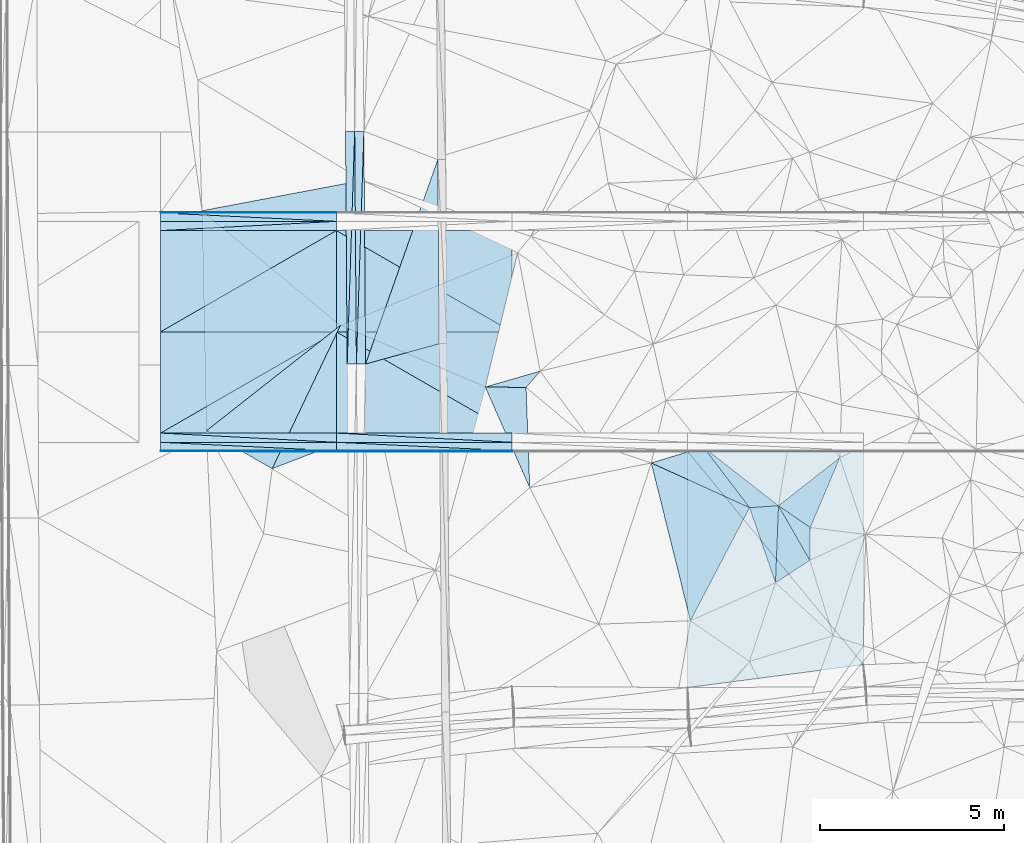
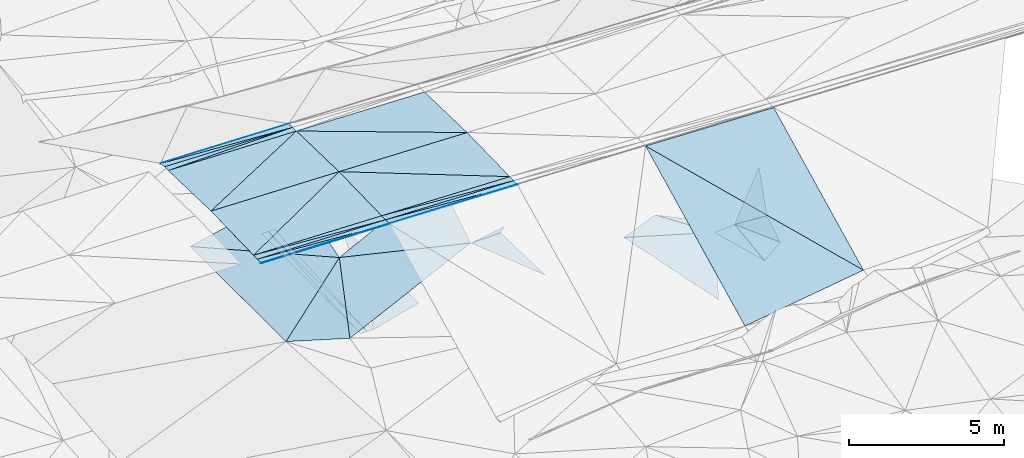
# One storey, part 102 of 275: 47 plates.
"""IFC2X3 building model written with IfcOpenShell, lengths in millimetres."""

from ifc_helpers import new_model, si_unit, frame, origin_with_axes, place, context, subcontext, project, spatial, polyline, outline, extrude, material, type_object, element, save


model = new_model("IFC2X3")

# Units and contexts
model_context = context("Model", 3, precision=1e-05, world=origin_with_axes())
body_context = subcontext(model_context, "Body", "Model", "MODEL_VIEW")
ifc_project = project(units=[si_unit("LENGTHUNIT", "METRE", prefix="MILLI"), si_unit("AREAUNIT", "SQUARE_METRE"), si_unit("VOLUMEUNIT", "CUBIC_METRE"), si_unit("MASSUNIT", "GRAM", prefix="KILO"), si_unit("TIMEUNIT", "SECOND"), si_unit("PLANEANGLEUNIT", "RADIAN"), si_unit("SOLIDANGLEUNIT", "STERADIAN"), si_unit("THERMODYNAMICTEMPERATUREUNIT", "DEGREE_CELSIUS"), si_unit("LUMINOUSINTENSITYUNIT", "LUMEN")], contexts=[model_context])

# Site, building, storey
site_placement = place(None, origin_with_axes())
site = spatial("IfcSite", under=ifc_project, at=site_placement, CompositionType="ELEMENT")
building_placement = place(site_placement, origin_with_axes())
building = spatial("IfcBuilding", under=site, at=building_placement, Name="Undefined", CompositionType="ELEMENT")
storey_placement = place(building_placement, origin_with_axes())
storey = spatial("IfcBuildingStorey", under=building, at=storey_placement, Name="Undefined", CompositionType="ELEMENT", Elevation=0.0)

# Plates
ifc_material = material()
plate_type_1 = type_object("IfcPlateType", PredefinedType="NOTDEFINED")
plate_1_placement = place(storey_placement, frame((-43702.2492212373, 60539.4072721862, 48388.7053414151), z_axis=(-0.0272311540100709, 0.0249844826056041, -0.999316886618159), x_axis=(-0.99962889120436, 5.71859775099965e-05, 0.0272410829319488)))
element("IfcPlate", 1, at=plate_1_placement, inside=storey, type_object=plate_type_1, material=ifc_material, Name="00_PR", context=body_context, shape_type="SweptSolid", body=[
    extrude(outline(polyline([(0.0, 0.0), (4773.92822265625, -9.19681042432785e-09), (4775.80078125, 2750.85864257813), (0.0, 0.0)])), frame((-8.85201319254618e-08, 2.18876761149539e-07, -0.5000001331573), z_axis=(0.0, 0.0, 1.0), x_axis=(1.0, 0.0, 0.0)), (0.0, 0.0, 1.0), 1.0),
])
plate_2_placement = place(storey_placement, frame((-48474.4044471993, 60539.6806812516, 48518.7523067115), z_axis=(-0.0245784152066993, 0.024986048500319, -0.999385610706031), x_axis=(-0.999697679469722, 5.72749763287614e-05, 0.0245875249350134)))
element("IfcPlate", 2, at=plate_2_placement, inside=storey, type_object=plate_type_1, material=ifc_material, Name="00_PR", context=body_context, shape_type="SweptSolid", body=[
    extrude(outline(polyline([(0.0, 0.0), (4773.6005859375, -1.37806637212634e-08), (1.69015407562256, 2750.85864257813), (0.0, 0.0)])), frame((-8.85201319254618e-08, 2.18876761149539e-07, -0.5000001331573), z_axis=(0.0, 0.0, 1.0), x_axis=(1.0, 0.0, 0.0)), (0.0, 0.0, 1.0), 1.0),
])
plate_3_placement = place(storey_placement, frame((-48474.2482148069, 63289.6807005516, 48587.502341085), z_axis=(-0.0272311540100709, 0.0249844826056041, -0.999316886618159), x_axis=(0.999628891063414, -5.72709766727029e-05, -0.0272410879254874)))
element("IfcPlate", 3, at=plate_3_placement, inside=storey, type_object=plate_type_1, material=ifc_material, Name="00_PR", context=body_context, shape_type="SweptSolid", body=[
    extrude(outline(polyline([(0.0, 0.0), (4773.92822265625, -9.19681042432785e-09), (4775.80078125, 2750.85864257813), (0.0, 0.0)])), frame((-8.85201319254618e-08, 2.18876761149539e-07, -0.5000001331573), z_axis=(0.0, 0.0, 1.0), x_axis=(1.0, 0.0, 0.0)), (0.0, 0.0, 1.0), 1.0),
])
plate_4_placement = place(storey_placement, frame((-53246.4043557416, 63289.9537042148, 48704.8733064667), z_axis=(-0.0245784152066993, 0.024986048500319, -0.999385610706031), x_axis=(0.999697679598014, -5.71899791955633e-05, -0.0245875199166873)))
element("IfcPlate", 4, at=plate_4_placement, inside=storey, type_object=plate_type_1, material=ifc_material, Name="00_PR", context=body_context, shape_type="SweptSolid", body=[
    extrude(outline(polyline([(0.0, 0.0), (4773.6005859375, -1.37806637212634e-08), (1.69015407562256, 2750.85864257813), (0.0, 0.0)])), frame((-8.85201319254618e-08, 2.18876761149539e-07, -0.5000001331573), z_axis=(0.0, 0.0, 1.0), x_axis=(1.0, 0.0, 0.0)), (0.0, 0.0, 1.0), 1.0),
])
plate_5_placement = place(storey_placement, frame((-43702.0916620227, 63289.3823089273, 48457.4553409828), z_axis=(-0.0272340175232394, -0.0249813615869036, -0.999316886609452), x_axis=(-0.99962889120436, 5.71859775099965e-05, 0.0272410829319488)))
element("IfcPlate", 5, at=plate_5_placement, inside=storey, type_object=plate_type_1, material=ifc_material, Name="00_PR", context=body_context, shape_type="SweptSolid", body=[
    extrude(outline(polyline([(0.0, 0.0), (4773.92822265625, -9.19681042432785e-09), (4772.05517578125, 2750.85864257813), (0.0, 0.0)])), frame((-8.85201319254618e-08, 2.18876761149539e-07, -0.5000001331573), z_axis=(0.0, 0.0, 1.0), x_axis=(1.0, 0.0, 0.0)), (0.0, 0.0, 1.0), 1.0),
])
plate_6_placement = place(storey_placement, frame((-48474.2468881017, 63289.655716543, 48587.5023062227), z_axis=(-0.0245812739924845, -0.0249832317354293, -0.999385610813444), x_axis=(-0.999697679469722, 5.72749763287614e-05, 0.0245875249350134)))
element("IfcPlate", 6, at=plate_6_placement, inside=storey, type_object=plate_type_1, material=ifc_material, Name="00_PR", context=body_context, shape_type="SweptSolid", body=[
    extrude(outline(polyline([(0.0, 0.0), (4773.6005859375, -1.37806637212634e-08), (-1.69062960147858, 2750.85864257813), (0.0, 0.0)])), frame((-8.85201319254618e-08, 2.18876761149539e-07, -0.5000001331573), z_axis=(0.0, 0.0, 1.0), x_axis=(1.0, 0.0, 0.0)), (0.0, 0.0, 1.0), 1.0),
])
plate_7_placement = place(storey_placement, frame((-48474.0906561354, 66039.655737399, 48518.7523406711), z_axis=(-0.0272340175232394, -0.0249813615869036, -0.999316886609452), x_axis=(0.999628891063414, -5.72709766727029e-05, -0.0272410879254874)))
element("IfcPlate", 7, at=plate_7_placement, inside=storey, type_object=plate_type_1, material=ifc_material, Name="00_PR", context=body_context, shape_type="SweptSolid", body=[
    extrude(outline(polyline([(0.0, 0.0), (4773.92822265625, -9.19681042432785e-09), (4772.05517578125, 2750.85864257813), (0.0, 0.0)])), frame((-8.85201319254618e-08, 2.18876761149539e-07, -0.5000001331573), z_axis=(0.0, 0.0, 1.0), x_axis=(1.0, 0.0, 0.0)), (0.0, 0.0, 1.0), 1.0),
])
plate_8_placement = place(storey_placement, frame((-53246.2467967621, 66039.9287394444, 48636.1233059961), z_axis=(-0.0245812739924845, -0.0249832317354293, -0.999385610813444), x_axis=(0.999697679598014, -5.71899791955633e-05, -0.0245875199166873)))
element("IfcPlate", 8, at=plate_8_placement, inside=storey, type_object=plate_type_1, material=ifc_material, Name="00_PR", context=body_context, shape_type="SweptSolid", body=[
    extrude(outline(polyline([(0.0, 0.0), (4773.6005859375, -1.37806637212634e-08), (-1.69062960147858, 2750.85864257813), (0.0, 0.0)])), frame((-8.85201319254618e-08, 2.18876761149539e-07, -0.5000001331573), z_axis=(0.0, 0.0, 1.0), x_axis=(1.0, 0.0, 0.0)), (0.0, 0.0, 1.0), 1.0),
])
plate_type_2 = type_object("IfcPlateType", PredefinedType="NOTDEFINED")
plate_9_placement = place(storey_placement, frame((-47928.7446048984, 62414.1431400305, 42632.1137235883), z_axis=(-0.0500701019869079, 0.0196605971016351, -0.998552174805417), x_axis=(-0.00717806700056212, 0.999773319631767, 0.0200445680076074)))
element("IfcPlate", 9, at=plate_9_placement, inside=storey, type_object=plate_type_2, material=ifc_material, Name="00_PR", context=body_context, shape_type="SweptSolid", body=[
    extrude(outline(polyline([(0.0, 0.0), (6322.61083984375, 6.27187546342611e-09), (6322.35986328125, 250.311706542969), (0.0, 0.0)])), frame((-8.85201319254618e-08, 2.18876761149539e-07, -0.5000001331573), z_axis=(0.0, 0.0, 1.0), x_axis=(1.0, 0.0, 0.0)), (0.0, 0.0, 1.0), 1.0),
])
plate_10_placement = place(storey_placement, frame((-47974.0937770389, 68735.320919189, 42758.8472000006), z_axis=(0.0198476279798522, 0.0201835783307846, -0.999599267121249), x_axis=(0.00717806702355623, -0.999773319631286, -0.0200445680233559)))
element("IfcPlate", 10, at=plate_10_placement, inside=storey, type_object=plate_type_2, material=ifc_material, Name="00_PR", context=body_context, shape_type="SweptSolid", body=[
    extrude(outline(polyline([(0.0, 0.0), (6322.61083984375, 6.27187546342611e-09), (6322.71142578125, 250.049118041992), (0.0, 0.0)])), frame((-8.85201319254618e-08, 2.18876761149539e-07, -0.5000001331573), z_axis=(0.0, 0.0, 1.0), x_axis=(1.0, 0.0, 0.0)), (0.0, 0.0, 1.0), 1.0),
])
plate_11_placement = place(storey_placement, frame((-47724.135640968, 68737.1149881538, 42746.347723686), z_axis=(-0.0500701019869079, 0.0196605971016351, -0.998552174805417), x_axis=(0.00717806702355623, -0.999773319631286, -0.0200445680233559)))
element("IfcPlate", 11, at=plate_11_placement, inside=storey, type_object=plate_type_2, material=ifc_material, Name="00_PR", context=body_context, shape_type="SweptSolid", body=[
    extrude(outline(polyline([(0.0, 0.0), (6322.6103515625, -2.52039171755314e-08), (6322.359375, 250.312637329102), (0.0, 0.0)])), frame((-8.85201319254618e-08, 2.18876761149539e-07, -0.5000001331573), z_axis=(0.0, 0.0, 1.0), x_axis=(1.0, 0.0, 0.0)), (0.0, 0.0, 1.0), 1.0),
])
plate_12_placement = place(storey_placement, frame((-48178.7023339839, 62412.3481564294, 42627.1132011494), z_axis=(0.0198476279798522, 0.0201835783307846, -0.999599267121249), x_axis=(-0.00717806700056212, 0.999773319631767, 0.0200445680076074)))
element("IfcPlate", 12, at=plate_12_placement, inside=storey, type_object=plate_type_2, material=ifc_material, Name="00_PR", context=body_context, shape_type="SweptSolid", body=[
    extrude(outline(polyline([(0.0, 0.0), (6322.611328125, 2.99114617519081e-08), (6322.71142578125, 250.050430297852), (0.0, 0.0)])), frame((-8.85201319254618e-08, 2.18876761149539e-07, -0.5000001331573), z_axis=(0.0, 0.0, 1.0), x_axis=(1.0, 0.0, 0.0)), (0.0, 0.0, 1.0), 1.0),
])
plate_13_placement = place(storey_placement, frame((-48474.0750078209, 66289.6557404895, 48512.5023086564), z_axis=(-0.0245812739924845, -0.0249832317354293, -0.999385610813444), x_axis=(-5.7277968073799e-05, -0.999687644772795, 0.0249921909375039)))
element("IfcPlate", 13, at=plate_13_placement, inside=storey, type_object=plate_type_2, material=ifc_material, Name="00_PR", context=body_context, shape_type="SweptSolid", body=[
    extrude(outline(polyline([(0.0, 0.0), (250.078109741211, 1.02591002359986e-09), (253.01188659668, 4773.599609375), (0.0, 0.0)])), frame((-8.85201319254618e-08, 2.18876761149539e-07, -0.5000001331573), z_axis=(0.0, 0.0, 1.0), x_axis=(1.0, 0.0, 0.0)), (0.0, 0.0, 1.0), 1.0),
])
plate_14_placement = place(storey_placement, frame((-43702.2635446846, 60289.4072713957, 48382.4553411027), z_axis=(-0.0272311540100709, 0.0249844826056041, -0.999316886618159), x_axis=(-0.99962889120436, 5.71859775099965e-05, 0.0272410829319488)))
element("IfcPlate", 14, at=plate_14_placement, inside=storey, type_object=plate_type_2, material=ifc_material, Name="00_PR", context=body_context, shape_type="SweptSolid", body=[
    extrude(outline(polyline([(0.0, 0.0), (4773.92822265625, -9.19681042432785e-09), (4774.0986328125, 250.078063964844), (0.0, 0.0)])), frame((-8.85201319254618e-08, 2.18876761149539e-07, -0.5000001331573), z_axis=(0.0, 0.0, 1.0), x_axis=(1.0, 0.0, 0.0)), (0.0, 0.0, 1.0), 1.0),
])
plate_15_placement = place(storey_placement, frame((-48474.4187714869, 60289.680680093, 48512.5023065268), z_axis=(-0.0245784152066993, 0.024986048500319, -0.999385610706031), x_axis=(-0.999697679469722, 5.72749763287614e-05, 0.0245875249350134)))
element("IfcPlate", 15, at=plate_15_placement, inside=storey, type_object=plate_type_2, material=ifc_material, Name="00_PR", context=body_context, shape_type="SweptSolid", body=[
    extrude(outline(polyline([(0.0, 0.0), (4773.6005859375, -1.37806637212634e-08), (4773.75439453125, 250.078063964844), (0.0, 0.0)])), frame((-8.85201319254618e-08, 2.18876761149539e-07, -0.5000001331573), z_axis=(0.0, 0.0, 1.0), x_axis=(1.0, 0.0, 0.0)), (0.0, 0.0, 1.0), 1.0),
])
plate_16_placement = place(storey_placement, frame((-48474.405774269, 60539.6806810252, 48518.7523407862), z_axis=(-0.0272311540100709, 0.0249844826056041, -0.999316886618159), x_axis=(0.999628891063414, -5.72709766727029e-05, -0.0272410879254874)))
element("IfcPlate", 16, at=plate_16_placement, inside=storey, type_object=plate_type_2, material=ifc_material, Name="00_PR", context=body_context, shape_type="SweptSolid", body=[
    extrude(outline(polyline([(0.0, 0.0), (4773.92822265625, -9.19681042432785e-09), (4774.0986328125, 250.078063964844), (0.0, 0.0)])), frame((-8.85201319254618e-08, 2.18876761149539e-07, -0.5000001331573), z_axis=(0.0, 0.0, 1.0), x_axis=(1.0, 0.0, 0.0)), (0.0, 0.0, 1.0), 1.0),
])
plate_17_placement = place(storey_placement, frame((-53246.5619147752, 60539.9536849169, 48636.123306196), z_axis=(-0.0245784152066993, 0.024986048500319, -0.999385610706031), x_axis=(0.999697679598014, -5.71899791955633e-05, -0.0245875199166873)))
element("IfcPlate", 17, at=plate_17_placement, inside=storey, type_object=plate_type_2, material=ifc_material, Name="00_PR", context=body_context, shape_type="SweptSolid", body=[
    extrude(outline(polyline([(0.0, 0.0), (4773.6005859375, -1.37806637212634e-08), (4773.75439453125, 250.078063964844), (0.0, 0.0)])), frame((-8.85201319254618e-08, 2.18876761149539e-07, -0.5000001331573), z_axis=(0.0, 0.0, 1.0), x_axis=(1.0, 0.0, 0.0)), (0.0, 0.0, 1.0), 1.0),
])
plate_18_placement = place(storey_placement, frame((-53246.2467967621, 66039.9287394444, 48636.1233059961), z_axis=(-0.0245812739924845, -0.0249832317354293, -0.999385610813444), x_axis=(5.72779774420735e-05, 0.999687644773175, -0.0249921909222736)))
element("IfcPlate", 18, at=plate_18_placement, inside=storey, type_object=plate_type_2, material=ifc_material, Name="00_PR", context=body_context, shape_type="SweptSolid", body=[
    extrude(outline(polyline([(0.0, 0.0), (250.078109741211, 1.02591002359986e-09), (253.01188659668, 4773.599609375), (0.0, 0.0)])), frame((-8.85201319254618e-08, 2.18876761149539e-07, -0.5000001331573), z_axis=(0.0, 0.0, 1.0), x_axis=(1.0, 0.0, 0.0)), (0.0, 0.0, 1.0), 1.0),
])
plate_type_3 = type_object("IfcPlateType", PredefinedType="NOTDEFINED")
plate_19_placement = place(storey_placement, frame((-45718.5217014855, 67965.8650167687, 42730.553100526), z_axis=(-0.000211585990932443, 0.0200601608976855, -0.999798752337753), x_axis=(0.00717820600795642, -0.999772985781101, -0.0200611629984491)))
element("IfcPlate", 19, at=plate_19_placement, inside=storey, type_object=plate_type_3, material=ifc_material, Name="00_PR", context=body_context, shape_type="SweptSolid", body=[
    extrude(outline(polyline([(0.0, 0.0), (5001.00634765625, -9.82254277914763e-09), (5536.82177734375, 2000.0), (0.0, 0.0)])), frame((-8.85201319254618e-08, 2.18876761149539e-07, -0.5000001331573), z_axis=(0.0, 0.0, 1.0), x_axis=(1.0, 0.0, 0.0)), (0.0, 0.0, 1.0), 1.0),
])
plate_type_4 = type_object("IfcPlateType", PredefinedType="NOTDEFINED")
plate_20_placement = place(storey_placement, frame((-48474.0606699531, 66539.6432736704, 48500.0027759916), z_axis=(-0.0245597254779007, -0.049920407621389, -0.998451186982801), x_axis=(-5.44309877651753e-05, -0.998752377894856, 0.0499368069327535)))
element("IfcPlate", 20, at=plate_20_placement, inside=storey, type_object=plate_type_4, material=ifc_material, Name="00_PR", context=body_context, shape_type="SweptSolid", body=[
    extrude(outline(polyline([(0.0, 0.0), (20.0253086090088, -9.45874489843845e-11), (25.8725299835205, 4773.59765625), (0.0, 0.0)])), frame((-8.85201319254618e-08, 2.18876761149539e-07, -0.5000001331573), z_axis=(0.0, 0.0, 1.0), x_axis=(1.0, 0.0, 0.0)), (0.0, 0.0, 1.0), 1.0),
])
plate_21_placement = place(storey_placement, frame((-53246.2196345515, 66519.9171631534, 48618.3737608729), z_axis=(-0.0245629215975469, -0.0493245660715372, -0.998480720927774), x_axis=(7.45959775313364e-05, 0.99878197432251, -0.0493412829572723)))
element("IfcPlate", 21, at=plate_21_placement, inside=storey, type_object=plate_type_4, material=ifc_material, Name="00_PR", context=body_context, shape_type="SweptSolid", body=[
    extrude(outline(polyline([(0.0, 0.0), (20.0237998962402, -1.01863406598568e-10), (25.8989391326904, 4773.59716796875), (0.0, 0.0)])), frame((-8.85201319254618e-08, 2.18876761149539e-07, -0.5000001331573), z_axis=(0.0, 0.0, 1.0), x_axis=(1.0, 0.0, 0.0)), (0.0, 0.0, 1.0), 1.0),
])
plate_22_placement = place(storey_placement, frame((-48474.4344069276, 60039.6931441328, 48500.0028086442), z_axis=(-0.0272042664867336, 0.0499195674072222, -0.998382674466457), x_axis=(8.74298351298379e-06, 0.998752329083408, 0.0499378120668911)))
element("IfcPlate", 22, at=plate_22_placement, inside=storey, type_object=plate_type_4, material=ifc_material, Name="00_PR", context=body_context, shape_type="SweptSolid", body=[
    extrude(outline(polyline([(0.0, 0.0), (20.0249061584473, -7.27595761418343e-11), (13.2997035980225, 4773.92431640625), (0.0, 0.0)])), frame((-8.85201319254618e-08, 2.18876761149539e-07, -0.5000001331573), z_axis=(0.0, 0.0, 1.0), x_axis=(1.0, 0.0, 0.0)), (0.0, 0.0, 1.0), 1.0),
])
plate_23_placement = place(storey_placement, frame((-53246.5905488345, 60039.9661501947, 48617.3737739148), z_axis=(-0.0245540067003085, 0.0499230862578922, -0.998451193706256), x_axis=(5.44309859502141e-05, 0.9987523778888, 0.0499368070538782)))
element("IfcPlate", 23, at=plate_23_placement, inside=storey, type_object=plate_type_4, material=ifc_material, Name="00_PR", context=body_context, shape_type="SweptSolid", body=[
    extrude(outline(polyline([(0.0, 0.0), (20.0253086090088, -9.45874489843845e-11), (14.1508646011353, 4773.59619140625), (0.0, 0.0)])), frame((-8.85201319254618e-08, 2.18876761149539e-07, -0.5000001331573), z_axis=(0.0, 0.0, 1.0), x_axis=(1.0, 0.0, 0.0)), (0.0, 0.0, 1.0), 1.0),
])
plate_24_placement = place(storey_placement, frame((-48474.4344069276, 60039.6931441328, 48500.0028086442), z_axis=(-0.0272042664867336, 0.0499195674072222, -0.998382674466457), x_axis=(0.999626040596747, 0.00413220701446374, -0.02703153391987)))
element("IfcPlate", 24, at=plate_24_placement, inside=storey, type_object=plate_type_4, material=ifc_material, Name="00_PR", context=body_context, shape_type="SweptSolid", body=[
    extrude(outline(polyline([(0.0, 0.0), (4773.94287109375, -7.6834112405777e-09), (4773.88623046875, 20.0252304077148), (0.0, 0.0)])), frame((-8.85201319254618e-08, 2.18876761149539e-07, -0.5000001331573), z_axis=(0.0, 0.0, 1.0), x_axis=(1.0, 0.0, 0.0)), (0.0, 0.0, 1.0), 1.0),
])
plate_25_placement = place(storey_placement, frame((-53246.5905488345, 60039.9661501947, 48617.3737739148), z_axis=(-0.0245540067003085, 0.0499230862578922, -0.998451193706256), x_axis=(0.999694272315039, 0.00413248801995345, -0.0243779499398386)))
element("IfcPlate", 25, at=plate_25_placement, inside=storey, type_object=plate_type_4, material=ifc_material, Name="00_PR", context=body_context, shape_type="SweptSolid", body=[
    extrude(outline(polyline([(0.0, 0.0), (4773.6171875, -1.63563527166843e-08), (4773.55859375, 20.0248203277588), (0.0, 0.0)])), frame((-8.85201319254618e-08, 2.18876761149539e-07, -0.5000001331573), z_axis=(0.0, 0.0, 1.0), x_axis=(1.0, 0.0, 0.0)), (0.0, 0.0, 1.0), 1.0),
])
plate_type_5 = type_object("IfcPlateType", PredefinedType="NOTDEFINED")
plate_26_placement = place(storey_placement, frame((-36464.6656981457, 58567.0068722737, 45169.6474914775), z_axis=(0.59324857018312, 0.388621128314232, -0.705003370632693), x_axis=(0.770384782548878, -0.528182354723398, 0.357114389203185)))
element("IfcPlate", 26, at=plate_26_placement, inside=storey, type_object=plate_type_5, material=ifc_material, Name="00", context=body_context, shape_type="SweptSolid", body=[
    extrude(outline(polyline([(0.0, 0.0), (1120.08923339844, 3.71073838323355e-09), (1403.45959472656, 981.173400878906), (0.0, 0.0)])), frame((-8.85201319254618e-08, 2.18876761149539e-07, -0.5000001331573), z_axis=(0.0, 0.0, 1.0), x_axis=(1.0, 0.0, 0.0)), (0.0, 0.0, 1.0), 1.0),
])
plate_type_6 = type_object("IfcPlateType", PredefinedType="NOTDEFINED")
plate_27_placement = place(storey_placement, frame((-48474.0617638406, 66519.6429474316, 48501.002775961), z_axis=(-0.0245597254779007, -0.049920407621389, -0.998451186982801), x_axis=(-5.74669840174811e-05, -0.998752333725473, 0.0499376869254844)))
element("IfcPlate", 27, at=plate_27_placement, inside=storey, type_object=plate_type_6, material=ifc_material, Name="00_PR", context=body_context, shape_type="SweptSolid", body=[
    extrude(outline(polyline([(0.0, 0.0), (230.287002563477, 1.30967237055302e-09), (5.861900806427, 4773.59765625), (0.0, 0.0)])), frame((-8.85201319254618e-08, 2.18876761149539e-07, -0.5000001331573), z_axis=(0.0, 0.0, 1.0), x_axis=(1.0, 0.0, 0.0)), (0.0, 0.0, 1.0), 1.0),
])
plate_28_placement = place(storey_placement, frame((-43702.2767658084, 60059.4200639155, 48370.95580801), z_axis=(-0.0272042645463556, 0.049920786795393, -0.998382613548644), x_axis=(-0.99962889120436, 5.71859775099965e-05, 0.0272410829319488)))
element("IfcPlate", 28, at=plate_28_placement, inside=storey, type_object=plate_type_6, material=ifc_material, Name="00_PR", context=body_context, shape_type="SweptSolid", body=[
    extrude(outline(polyline([(0.0, 0.0), (4773.92919921875, 1.85536919161677e-09), (4774.2412109375, 230.287185668945), (0.0, 0.0)])), frame((-8.85201319254618e-08, 2.18876761149539e-07, -0.5000001331573), z_axis=(0.0, 0.0, 1.0), x_axis=(1.0, 0.0, 0.0)), (0.0, 0.0, 1.0), 1.0),
])
plate_29_placement = place(storey_placement, frame((-48474.4329079842, 60059.6930685664, 48501.0027735423), z_axis=(-0.0245540062307826, 0.0499240404594116, -0.998451146006767), x_axis=(-0.999697679469722, 5.72749763287614e-05, 0.0245875249350134)))
element("IfcPlate", 29, at=plate_29_placement, inside=storey, type_object=plate_type_6, material=ifc_material, Name="00_PR", context=body_context, shape_type="SweptSolid", body=[
    extrude(outline(polyline([(0.0, 0.0), (4773.599609375, 1.40644260682166e-08), (4773.88232421875, 230.286819458008), (0.0, 0.0)])), frame((-8.85201319254618e-08, 2.18876761149539e-07, -0.5000001331573), z_axis=(0.0, 0.0, 1.0), x_axis=(1.0, 0.0, 0.0)), (0.0, 0.0, 1.0), 1.0),
])
plate_30_placement = place(storey_placement, frame((-48474.4200845118, 60289.6931481707, 48512.5028077305), z_axis=(-0.0272042645463556, 0.049920786795393, -0.998382613548644), x_axis=(0.999628891063414, -5.72709766727029e-05, -0.0272410879254874)))
element("IfcPlate", 30, at=plate_30_placement, inside=storey, type_object=plate_type_6, material=ifc_material, Name="00_PR", context=body_context, shape_type="SweptSolid", body=[
    extrude(outline(polyline([(0.0, 0.0), (4773.92822265625, -9.19681042432785e-09), (4774.2412109375, 230.28678894043), (0.0, 0.0)])), frame((-8.85201319254618e-08, 2.18876761149539e-07, -0.5000001331573), z_axis=(0.0, 0.0, 1.0), x_axis=(1.0, 0.0, 0.0)), (0.0, 0.0, 1.0), 1.0),
])
plate_31_placement = place(storey_placement, frame((-53246.5762263919, 60289.9661533307, 48629.8737730848), z_axis=(-0.0245540062307826, 0.0499240404594116, -0.998451146006767), x_axis=(0.999697679598014, -5.71899791955633e-05, -0.0245875199166873)))
element("IfcPlate", 31, at=plate_31_placement, inside=storey, type_object=plate_type_6, material=ifc_material, Name="00_PR", context=body_context, shape_type="SweptSolid", body=[
    extrude(outline(polyline([(0.0, 0.0), (4773.6005859375, -1.37806637212634e-08), (4773.88232421875, 230.287231445313), (0.0, 0.0)])), frame((-8.85201319254618e-08, 2.18876761149539e-07, -0.5000001331573), z_axis=(0.0, 0.0, 1.0), x_axis=(1.0, 0.0, 0.0)), (0.0, 0.0, 1.0), 1.0),
])
plate_32_placement = place(storey_placement, frame((-48474.0749951679, 66289.6432696918, 48512.5027736048), z_axis=(-0.0245597254779007, -0.049920407621389, -0.998451186982801), x_axis=(-0.999697679469722, 5.72749763287614e-05, 0.0245875249350134)))
element("IfcPlate", 32, at=plate_32_placement, inside=storey, type_object=plate_type_6, material=ifc_material, Name="00_PR", context=body_context, shape_type="SweptSolid", body=[
    extrude(outline(polyline([(0.0, 0.0), (4773.6005859375, -1.37806637212634e-08), (4773.318359375, 230.287734985352), (0.0, 0.0)])), frame((-8.85201319254618e-08, 2.18876761149539e-07, -0.5000001331573), z_axis=(0.0, 0.0, 1.0), x_axis=(1.0, 0.0, 0.0)), (0.0, 0.0, 1.0), 1.0),
])
plate_type_7 = type_object("IfcPlateType", PredefinedType="NOTDEFINED")
plate_33_placement = place(storey_placement, frame((-37250.9171089781, 58514.6021908734, 45159.5043516397), z_axis=(0.0545659013610374, 0.119912587672956, -0.991283780623003), x_axis=(-0.910194319619657, 0.414181482604075, -1.19508510881298e-10)))
element("IfcPlate", 33, at=plate_33_placement, inside=storey, type_object=plate_type_7, material=ifc_material, Name="00", context=body_context, shape_type="SweptSolid", body=[
    extrude(outline(polyline([(0.0, 0.0), (2932.3369140625, 5.19503373652697e-09), (1820.35693359375, 986.762634277344), (0.0, 0.0)])), frame((-8.85201319254618e-08, 2.18876761149539e-07, -0.5000001331573), z_axis=(0.0, 0.0, 1.0), x_axis=(1.0, 0.0, 0.0)), (0.0, 0.0, 1.0), 1.0),
])
plate_type_8 = type_object("IfcPlateType", PredefinedType="NOTDEFINED")
plate_34_placement = place(storey_placement, frame((-34158.2961508491, 54249.3501023105, 45177.0479763329), z_axis=(-0.0290853992438746, 0.447025672809662, -0.894048146018934), x_axis=(-0.589166577060893, 0.714877563002214, 0.376606976024564)))
element("IfcPlate", 34, at=plate_34_placement, inside=storey, type_object=plate_type_8, material=ifc_material, Name="00_PR", context=body_context, shape_type="SweptSolid", body=[
    extrude(outline(polyline([(0.0, 0.0), (8099.28173828125, 2.1616870071739e-08), (5228.970703125, 3815.619140625), (0.0, 0.0)])), frame((-8.85201319254618e-08, 2.18876761149539e-07, -0.5000001331573), z_axis=(0.0, 0.0, 1.0), x_axis=(1.0, 0.0, 0.0)), (0.0, 0.0, 1.0), 1.0),
])
plate_type_9 = type_object("IfcPlateType", PredefinedType="NOTDEFINED")
plate_35_placement = place(storey_placement, frame((-34158.2961508491, 54249.3501023105, 45177.0479763329), z_axis=(-0.0290853992438746, 0.447025672809662, -0.894048146018934), x_axis=(-0.991147357857753, -0.128811913984099, -0.0321621800776823)))
element("IfcPlate", 35, at=plate_35_placement, inside=storey, type_object=plate_type_9, material=ifc_material, Name="00_PR", context=body_context, shape_type="SweptSolid", body=[
    extrude(outline(polyline([(0.0, 0.0), (4814.81689453125, 1.49302650243044e-08), (3885.65991210938, 7106.3359375), (0.0, 0.0)])), frame((-8.85201319254618e-08, 2.18876761149539e-07, -0.5000001331573), z_axis=(0.0, 0.0, 1.0), x_axis=(1.0, 0.0, 0.0)), (0.0, 0.0, 1.0), 1.0),
])
plate_type_10 = type_object("IfcPlateType", PredefinedType="NOTDEFINED")
plate_36_placement = place(storey_placement, frame((-42935.6992798643, 62222.4201416377, 45139.5282327581), z_axis=(0.0133253053844914, -0.331050632072888, -0.943518900309131), x_axis=(-0.63425028573065, -0.732280249585255, 0.247976230953585)))
element("IfcPlate", 36, at=plate_36_placement, inside=storey, type_object=plate_type_10, material=ifc_material, Name="00", context=body_context, shape_type="SweptSolid", body=[
    extrude(outline(polyline([(0.0, 0.0), (604.896667480469, -3.49245965480804e-10), (1294.7666015625, 869.585876464844), (0.0, 0.0)])), frame((-8.85201319254618e-08, 2.18876761149539e-07, -0.5000001331573), z_axis=(0.0, 0.0, 1.0), x_axis=(1.0, 0.0, 0.0)), (0.0, 0.0, 1.0), 1.0),
])
plate_type_11 = type_object("IfcPlateType", PredefinedType="NOTDEFINED")
plate_37_placement = place(storey_placement, frame((-35612.9493559835, 57084.7956504721, 45069.5011115482), z_axis=(-0.00086995556450506, 0.0668231239222434, -0.997764457818872), x_axis=(-0.836767057174757, -0.546383307198402, -0.035863263125851)))
element("IfcPlate", 37, at=plate_37_placement, inside=storey, type_object=plate_type_11, material=ifc_material, Name="00", context=body_context, shape_type="SweptSolid", body=[
    extrude(outline(polyline([(0.0, 0.0), (1115.34753417969, -6.25732354819775e-10), (-100.417137145996, 1709.47839355469), (0.0, 0.0)])), frame((-8.85201319254618e-08, 2.18876761149539e-07, -0.5000001331573), z_axis=(0.0, 0.0, 1.0), x_axis=(1.0, 0.0, 0.0)), (0.0, 0.0, 1.0), 1.0),
])
plate_type_12 = type_object("IfcPlateType", PredefinedType="NOTDEFINED")
plate_38_placement = place(storey_placement, frame((-43220.1166381821, 59057.299973369, 45229.5002048454), z_axis=(0.0182666223376928, 0.0226963442544646, -0.99957551313838), x_axis=(-0.404307418437397, 0.914525327433927, 0.0133767289856498)))
element("IfcPlate", 38, at=plate_38_placement, inside=storey, type_object=plate_type_12, material=ifc_material, Name="00", context=body_context, shape_type="SweptSolid", body=[
    extrude(outline(polyline([(0.0, 0.0), (2990.267578125, 7.95989762991667e-09), (2530.576171875, 1010.33850097656), (0.0, 0.0)])), frame((-8.85201319254618e-08, 2.18876761149539e-07, -0.5000001331573), z_axis=(0.0, 0.0, 1.0), x_axis=(1.0, 0.0, 0.0)), (0.0, 0.0, 1.0), 1.0),
])
plate_type_13 = type_object("IfcPlateType", PredefinedType="NOTDEFINED")
plate_39_placement = place(storey_placement, frame((-36546.2308118449, 56475.3882275174, 45029.5011164015), z_axis=(0.00827408888965656, 0.0664671133633009, -0.997754309584377), x_axis=(-0.326037811654392, 0.943441516977837, 0.0601452360056361)))
element("IfcPlate", 39, at=plate_39_placement, inside=storey, type_object=plate_type_13, material=ifc_material, Name="00", context=body_context, shape_type="SweptSolid", body=[
    extrude(outline(polyline([(0.0, 0.0), (2161.43481445313, -5.03496266901493e-09), (1955.09033203125, 760.277587890625), (0.0, 0.0)])), frame((-8.85201319254618e-08, 2.18876761149539e-07, -0.5000001331573), z_axis=(0.0, 0.0, 1.0), x_axis=(1.0, 0.0, 0.0)), (0.0, 0.0, 1.0), 1.0),
])
plate_type_14 = type_object("IfcPlateType", PredefinedType="NOTDEFINED")
plate_40_placement = place(storey_placement, frame((-48361.2962935922, 63464.859372148, 45059.5004840722), z_axis=(0.0435119968802435, 0.00860554050769361, -0.999015841115677), x_axis=(-0.76996901966745, 0.637464665744082, -0.02804476208013)))
element("IfcPlate", 40, at=plate_40_placement, inside=storey, type_object=plate_type_14, material=ifc_material, Name="00", context=body_context, shape_type="SweptSolid", body=[
    extrude(outline(polyline([(0.0, 0.0), (4885.0478515625, -1.38243194669485e-10), (2047.93908691406, 3417.41796875), (0.0, 0.0)])), frame((-8.85201319254618e-08, 2.18876761149539e-07, -0.5000001331573), z_axis=(0.0, 0.0, 1.0), x_axis=(1.0, 0.0, 0.0)), (0.0, 0.0, 1.0), 1.0),
])
plate_type_15 = type_object("IfcPlateType", PredefinedType="NOTDEFINED")
plate_41_placement = place(storey_placement, frame((-38502.6829156678, 60158.8597832231, 45289.5017797591), z_axis=(0.00707993462264799, 0.0841693950861314, -0.996426308091358), x_axis=(0.787171023904515, -0.614990170907429, -0.0463558929627067)))
element("IfcPlate", 41, at=plate_41_placement, inside=storey, type_object=plate_type_15, material=ifc_material, Name="00", context=body_context, shape_type="SweptSolid", body=[
    extrude(outline(polyline([(0.0, 0.0), (2588.66772460938, 2.87400325760245e-09), (2002.57458496094, 526.398132324219), (0.0, 0.0)])), frame((-8.85201319254618e-08, 2.18876761149539e-07, -0.5000001331573), z_axis=(0.0, 0.0, 1.0), x_axis=(1.0, 0.0, 0.0)), (0.0, 0.0, 1.0), 1.0),
])
plate_type_16 = type_object("IfcPlateType", PredefinedType="NOTDEFINED")
plate_42_placement = place(storey_placement, frame((-35601.8393925625, 57975.2246112966, 45569.5531872601), z_axis=(0.446383091714861, 0.0468867723696831, -0.893612760656335), x_axis=(-0.770384782548169, 0.528182354722608, -0.357114389205884)))
element("IfcPlate", 42, at=plate_42_placement, inside=storey, type_object=plate_type_16, material=ifc_material, Name="00", context=body_context, shape_type="SweptSolid", body=[
    extrude(outline(polyline([(0.0, 0.0), (1120.08923339844, 3.71073838323355e-09), (205.251495361328, 2108.54736328125), (0.0, 0.0)])), frame((-8.85201319254618e-08, 2.18876761149539e-07, -0.5000001331573), z_axis=(0.0, 0.0, 1.0), x_axis=(1.0, 0.0, 0.0)), (0.0, 0.0, 1.0), 1.0),
])
plate_type_17 = type_object("IfcPlateType", PredefinedType="NOTDEFINED")
plate_43_placement = place(storey_placement, frame((-52003.5818293369, 60601.6311497493, 44758.501096054), z_axis=(0.0599972981086269, 0.0285714510556933, -0.997789555168943), x_axis=(-0.019904234591276, 0.999425777677211, 0.0274214580144339)))
element("IfcPlate", 43, at=plate_43_placement, inside=storey, type_object=plate_type_17, material=ifc_material, Name="00", context=body_context, shape_type="SweptSolid", body=[
    extrude(outline(polyline([(0.0, 0.0), (5980.7177734375, 1.45737431012094e-08), (2797.35083007813, 3705.38330078125), (0.0, 0.0)])), frame((-8.85201319254618e-08, 2.18876761149539e-07, -0.5000001331573), z_axis=(0.0, 0.0, 1.0), x_axis=(1.0, 0.0, 0.0)), (0.0, 0.0, 1.0), 1.0),
])
plate_type_18 = type_object("IfcPlateType", PredefinedType="NOTDEFINED")
plate_44_placement = place(storey_placement, frame((-44429.0832532868, 61791.971596709, 45269.500942407), z_axis=(0.0597399886351385, 0.0151289108165127, -0.998099318612822), x_axis=(-0.931936815406082, -0.357419401438412, -0.0611975781071281)))
element("IfcPlate", 44, at=plate_44_placement, inside=storey, type_object=plate_type_18, material=ifc_material, Name="00", context=body_context, shape_type="SweptSolid", body=[
    extrude(outline(polyline([(0.0, 0.0), (6209.39599609375, -1.52504071593285e-08), (3079.49438476563, 2970.12036132813), (0.0, 0.0)])), frame((-8.85201319254618e-08, 2.18876761149539e-07, -0.5000001331573), z_axis=(0.0, 0.0, 1.0), x_axis=(1.0, 0.0, 0.0)), (0.0, 0.0, 1.0), 1.0),
])
plate_type_19 = type_object("IfcPlateType", PredefinedType="NOTDEFINED")
plate_45_placement = place(storey_placement, frame((-44429.0857763179, 61791.965643153, 45269.5007435492), z_axis=(0.0546963021016209, 0.0032234761382464, -0.998497833617076), x_axis=(-0.919078194797501, 0.391006497242346, -0.0490835100826987)))
element("IfcPlate", 45, at=plate_45_placement, inside=storey, type_object=plate_type_19, material=ifc_material, Name="00", context=body_context, shape_type="SweptSolid", body=[
    extrude(outline(polyline([(0.0, 0.0), (4278.42236328125, -3.08500602841377e-09), (614.104858398438, 3702.06372070313), (0.0, 0.0)])), frame((-8.85201319254618e-08, 2.18876761149539e-07, -0.5000001331573), z_axis=(0.0, 0.0, 1.0), x_axis=(1.0, 0.0, 0.0)), (0.0, 0.0, 1.0), 1.0),
])
plate_type_20 = type_object("IfcPlateType", PredefinedType="NOTDEFINED")
plate_46_placement = place(storey_placement, frame((-48361.2795481859, 63464.8584993852, 45059.5014882984), z_axis=(0.0770037861436993, 0.00685544328782735, -0.997007231577015), x_axis=(-0.429809014560268, -0.902059832481513, -0.0393988531071179)))
element("IfcPlate", 46, at=plate_46_placement, inside=storey, type_object=plate_type_20, material=ifc_material, Name="00", context=body_context, shape_type="SweptSolid", body=[
    extrude(outline(polyline([(0.0, 0.0), (4314.8466796875, -3.97267285734415e-09), (4160.162109375, 2061.08959960938), (0.0, 0.0)])), frame((-8.85201319254618e-08, 2.18876761149539e-07, -0.5000001331573), z_axis=(0.0, 0.0, 1.0), x_axis=(1.0, 0.0, 0.0)), (0.0, 0.0, 1.0), 1.0),
])
plate_type_21 = type_object("IfcPlateType", PredefinedType="NOTDEFINED")
plate_47_placement = place(storey_placement, frame((-39919.9264985704, 59729.0933919479, 45159.5011911817), z_axis=(0.0286576352744348, 0.0629772642927189, -0.997603430288149), x_axis=(0.910194319609807, -0.414181482625721, 1.44115393661505e-10)))
element("IfcPlate", 47, at=plate_47_placement, inside=storey, type_object=plate_type_21, material=ifc_material, Name="00", context=body_context, shape_type="SweptSolid", body=[
    extrude(outline(polyline([(0.0, 0.0), (2932.3369140625, 5.19503373652697e-09), (2743.375, 3468.65869140625), (0.0, 0.0)])), frame((-8.85201319254618e-08, 2.18876761149539e-07, -0.5000001331573), z_axis=(0.0, 0.0, 1.0), x_axis=(1.0, 0.0, 0.0)), (0.0, 0.0, 1.0), 1.0),
])

save(model, "model.ifc")
